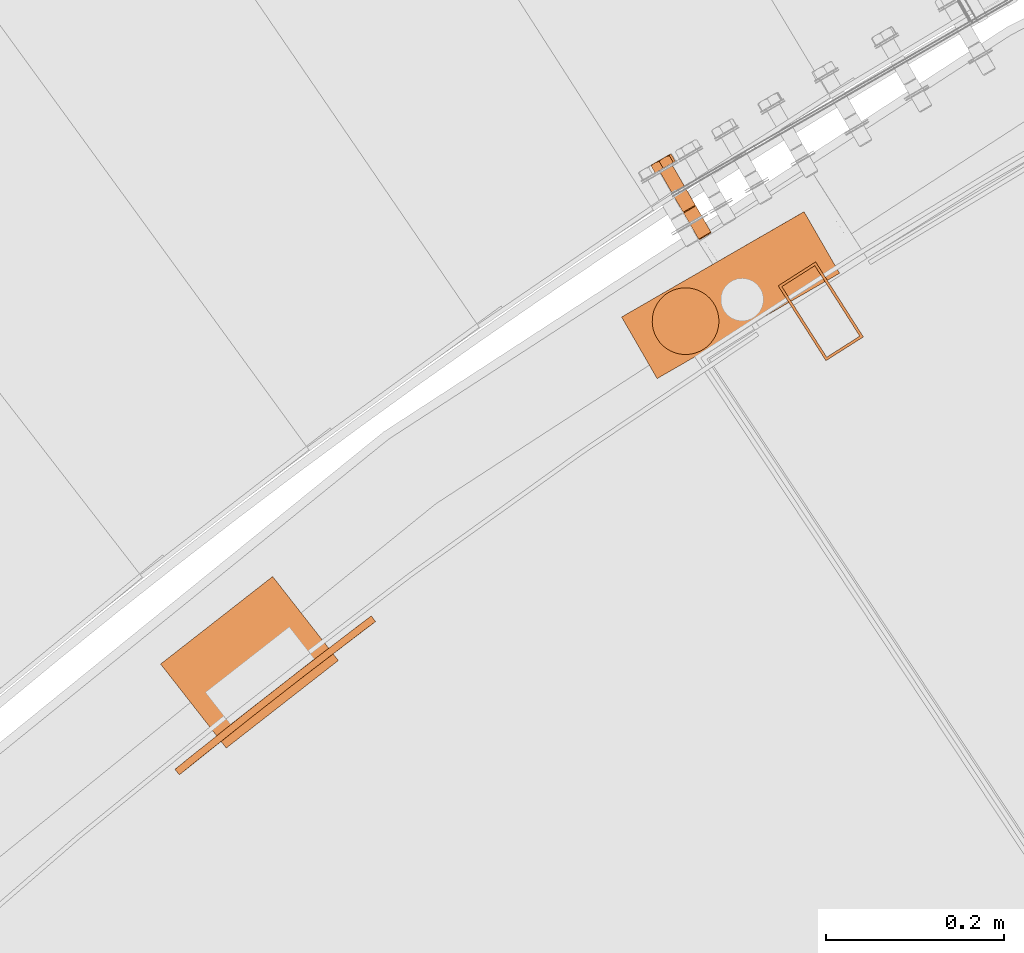
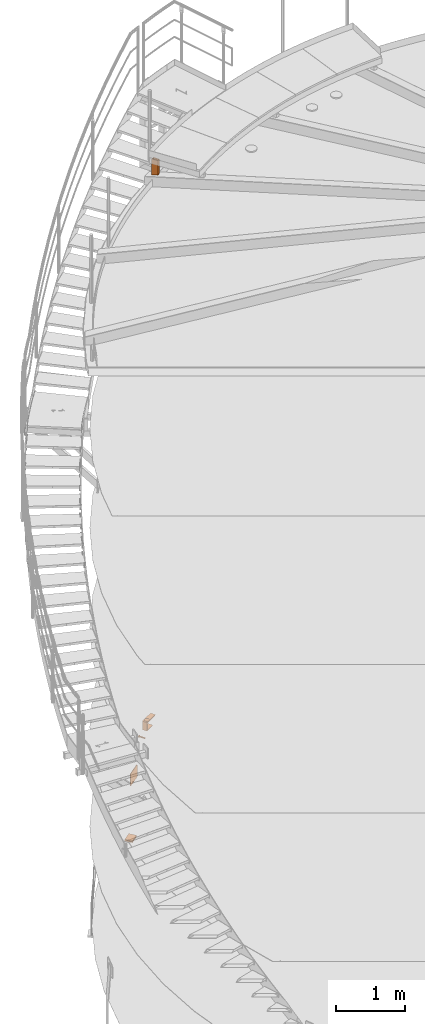
# One storey, part 77 of 126: 6 proxies.
"""IFC2X3 building model written with IfcOpenShell, lengths in millimetres."""

from ifc_helpers import new_model, si_unit, origin, origin_with_axes, place, context, project, spatial, faceted_brep, material, element, save


model = new_model("IFC2X3")

# Units and contexts
context_of_model_1 = context(None, 3, precision=0.1, world=origin())
context_of_model_2 = context(None, 3, precision=0.1, world=origin())
ifc_project = project(units=[si_unit("LENGTHUNIT", "METRE", prefix="MILLI"), si_unit("AREAUNIT", "SQUARE_METRE", prefix="CENTI"), si_unit("VOLUMEUNIT", "CUBIC_METRE", prefix="CENTI"), si_unit("MASSUNIT", "GRAM", prefix="KILO")], contexts=[context_of_model_1, context_of_model_2])

# Site, building, storey
site_placement = place(None, origin_with_axes())
site = spatial("IfcSite", under=ifc_project, at=site_placement, CompositionType="ELEMENT")
building_placement = place(site_placement, origin_with_axes())
building = spatial("IfcBuilding", under=site, at=building_placement, CompositionType="ELEMENT")
storey_placement = place(building_placement, origin_with_axes())
storey = spatial("IfcBuildingStorey", under=building, at=storey_placement, CompositionType="ELEMENT")

# Proxies
ifc_material = material(Name="STAHL")
proxy_1_placement = place(storey_placement, origin_with_axes())
element("IfcBuildingElementProxy", 1, at=proxy_1_placement, inside=storey, material=ifc_material, Name="profile", context=context_of_model_2, shape_type="Brep", body=[
    faceted_brep([(3665.8, 14681.7, 771.5), (3666.0, 14681.8, 769.6), (3667.4, 14681.4, 769.8), (3667.3, 14681.3, 771.5), (3666.1, 14681.9, 773.4), (3667.5, 14681.4, 773.1), (3666.8, 14682.2, 775.2), (3668.1, 14681.8, 774.7), (3667.8, 14682.8, 776.7), (3669.0, 14682.3, 776.0), (3669.1, 14683.6, 778.0), (3670.1, 14682.9, 777.0), (3670.6, 14684.5, 778.8), (3671.4, 14683.7, 777.8), (3672.2, 14685.4, 779.2), (3672.8, 14684.5, 778.1), (3673.9, 14686.4, 779.1), (3674.3, 14685.3, 778.0), (3675.5, 14687.3, 778.5), (3675.7, 14686.1, 777.5), (3676.9, 14688.1, 777.5), (3676.9, 14686.9, 776.7), (3678.1, 14688.8, 776.2), (3678.0, 14687.5, 775.5), (3679.0, 14689.3, 774.6), (3678.7, 14687.9, 774.1), (3679.5, 14689.6, 772.7), (3679.2, 14688.2, 772.5), (3648.3, 14712.0, 771.5), (3648.5, 14712.1, 769.6), (3649.9, 14711.7, 769.8), (3649.8, 14711.6, 771.5), (3648.6, 14712.2, 773.4), (3650.0, 14711.8, 773.1), (3649.3, 14712.6, 775.2), (3650.6, 14712.1, 774.7), (3650.3, 14713.1, 776.7), (3651.5, 14712.6, 776.0), (3651.6, 14713.9, 778.0), (3652.6, 14713.2, 777.0), (3653.1, 14714.8, 778.8), (3653.9, 14714.0, 777.8), (3654.7, 14715.7, 779.2), (3655.3, 14714.8, 778.1), (3656.4, 14716.7, 779.1), (3656.8, 14715.6, 778.0), (3658.0, 14717.6, 778.5), (3658.2, 14716.4, 777.5), (3659.4, 14718.4, 777.5), (3659.4, 14717.2, 776.7), (3660.6, 14719.1, 776.2), (3660.5, 14717.8, 775.5), (3661.5, 14719.6, 774.6), (3661.2, 14718.2, 774.1), (3662.0, 14719.9, 772.7), (3661.7, 14718.5, 772.5), (3679.7, 14689.7, 770.8), (3662.7, 14719.1, 770.8), (3662.6, 14719.0, 772.7), (3679.4, 14689.5, 768.9), (3662.4, 14718.9, 768.9), (3678.7, 14689.2, 767.1), (3661.8, 14718.5, 767.1), (3677.7, 14688.6, 765.6), (3660.8, 14717.9, 765.6), (3676.4, 14687.8, 764.4), (3659.5, 14717.2, 764.4), (3674.9, 14686.9, 763.6), (3658.0, 14716.3, 763.6), (3673.3, 14686.0, 763.2), (3656.3, 14715.4, 763.2), (3671.6, 14685.0, 763.3), (3654.6, 14714.4, 763.3), (3670.0, 14684.1, 763.8), (3653.0, 14713.5, 763.8), (3668.6, 14683.3, 764.8), (3651.6, 14712.7, 764.8), (3667.4, 14682.6, 766.1), (3650.4, 14712.0, 766.1), (3666.5, 14682.1, 767.8), (3649.5, 14711.5, 767.8), (3649.0, 14711.2, 769.6), (3634.6, 14766.3, 774.6), (3633.7, 14765.8, 776.2), (3635.1, 14766.6, 772.7), (3621.4, 14758.7, 771.5), (3621.5, 14758.8, 769.6), (3621.6, 14758.9, 773.4), (3622.3, 14759.3, 775.2), (3623.3, 14759.8, 776.7), (3624.6, 14760.6, 778.0), (3626.1, 14761.5, 778.8), (3627.8, 14762.4, 779.2), (3629.4, 14763.4, 779.1), (3631.0, 14764.3, 778.5), (3632.5, 14765.1, 777.5), (3649.0, 14712.4, 767.8), (3622.0, 14759.1, 767.8), (3622.9, 14759.6, 766.1), (3649.9, 14712.9, 766.1), (3662.2, 14720.0, 770.8), (3635.2, 14766.7, 770.8), (3661.9, 14719.8, 768.9), (3634.9, 14766.5, 768.9), (3661.2, 14719.5, 767.1), (3634.3, 14766.2, 767.1), (3660.2, 14718.9, 765.6), (3633.3, 14765.6, 765.6), (3658.9, 14718.1, 764.4), (3632.0, 14764.8, 764.4), (3657.4, 14717.3, 763.6), (3630.5, 14764.0, 763.6), (3655.8, 14716.3, 763.2), (3628.8, 14763.0, 763.2), (3654.1, 14715.4, 763.3), (3627.1, 14762.0, 763.3), (3652.5, 14714.4, 763.8), (3625.5, 14761.1, 763.8), (3651.1, 14713.6, 764.8), (3624.1, 14760.3, 764.8), (3616.9, 14756.1, 775.6), (3619.3, 14757.5, 762.0), (3630.6, 14764.1, 757.6), (3639.7, 14769.3, 766.7), (3637.3, 14767.9, 780.3), (3626.0, 14761.4, 784.8), (3626.2, 14771.8, 757.6), (3627.2, 14773.0, 758.9), (3628.3, 14774.0, 760.2), (3629.2, 14774.7, 761.2), (3630.1, 14775.3, 762.2), (3631.4, 14776.0, 763.4), (3632.8, 14776.5, 764.7), (3633.9, 14776.8, 765.7), (3635.2, 14777.0, 766.7), (3631.4, 14776.0, 763.7), (3632.4, 14776.6, 765.4), (3633.1, 14777.1, 767.3), (3633.6, 14777.3, 769.4), (3633.7, 14777.4, 771.4), (3633.8, 14777.4, 772.0), (3634.1, 14777.4, 770.5), (3634.6, 14777.2, 768.7), (3633.5, 14777.3, 773.5), (3620.0, 14769.4, 759.8), (3621.7, 14770.5, 759.3), (3623.5, 14771.5, 759.2), (3625.3, 14772.5, 759.4), (3627.1, 14773.5, 760.0), (3628.7, 14774.5, 760.9), (3624.6, 14771.4, 758.1), (3623.2, 14770.9, 758.6), (3621.5, 14770.3, 759.2), (3614.8, 14765.2, 762.0), (3614.3, 14765.4, 763.6), (3613.9, 14765.6, 765.1), (3613.5, 14765.6, 767.0), (3613.1, 14765.5, 768.8), (3613.6, 14765.8, 766.8), (3614.4, 14766.2, 765.0), (3615.5, 14766.9, 763.3), (3616.8, 14767.6, 761.8), (3618.3, 14768.5, 760.7), (3618.7, 14768.7, 760.3), (3617.6, 14767.8, 760.8), (3616.2, 14766.6, 761.4), (3633.2, 14777.0, 775.4), (3633.0, 14776.6, 777.2), (3632.9, 14776.2, 778.8), (3632.9, 14775.6, 780.3), (3631.0, 14775.1, 781.0), (3629.2, 14774.5, 781.6), (3627.9, 14774.0, 782.1), (3626.6, 14773.3, 782.5), (3625.1, 14772.3, 783.1), (3623.7, 14771.2, 783.8), (3622.6, 14770.2, 784.3), (3621.5, 14769.1, 784.8), (3612.5, 14763.9, 775.6), (3613.3, 14764.8, 776.7), (3614.1, 14765.7, 777.7), (3615.3, 14766.6, 779.0), (3616.4, 14767.4, 780.2), (3615.2, 14766.7, 778.7), (3614.2, 14766.1, 776.9), (3613.5, 14765.7, 775.0), (3613.0, 14765.4, 773.0), (3612.9, 14765.4, 770.9), (3612.9, 14765.3, 770.3), (3612.7, 14765.0, 771.8), (3612.5, 14764.5, 773.7), (3617.5, 14767.9, 781.2), (3618.5, 14768.4, 782.2), (3619.9, 14768.8, 783.5), (3624.9, 14772.3, 783.0), (3623.1, 14771.2, 783.2), (3621.3, 14770.2, 782.9), (3619.5, 14769.2, 782.4), (3617.9, 14768.3, 781.4), (3628.3, 14774.3, 781.7), (3633.0, 14777.0, 775.5), (3632.2, 14776.5, 777.4), (3631.1, 14775.9, 779.1), (3629.8, 14775.1, 780.5), (3648.9, 14711.1, 771.5), (3649.1, 14711.2, 773.4), (3649.8, 14711.6, 775.2), (3650.8, 14712.2, 776.7), (3652.1, 14713.0, 778.0), (3653.6, 14713.8, 778.8), (3655.3, 14714.8, 779.2), (3656.9, 14715.7, 779.1), (3658.5, 14716.7, 778.5), (3660.0, 14717.5, 777.5), (3661.2, 14718.2, 776.2), (3662.1, 14718.7, 774.6), (3650.4, 14711.9, 768.2), (3651.1, 14712.4, 766.8), (3652.2, 14713.0, 765.7), (3653.4, 14713.7, 764.8), (3654.8, 14714.5, 764.4), (3656.2, 14715.3, 764.3), (3657.7, 14716.2, 764.6), (3659.0, 14716.9, 765.3), (3660.1, 14717.6, 766.4), (3661.0, 14718.1, 767.7), (3661.5, 14718.4, 769.2), (3661.8, 14718.5, 770.9), (3667.9, 14681.6, 768.2), (3668.6, 14682.1, 766.8), (3669.7, 14682.7, 765.7), (3670.9, 14683.4, 764.8), (3672.3, 14684.2, 764.4), (3673.7, 14685.0, 764.3), (3675.2, 14685.8, 764.6), (3676.5, 14686.6, 765.3), (3677.6, 14687.2, 766.4), (3678.5, 14687.8, 767.7), (3679.0, 14688.1, 769.2), (3679.3, 14688.2, 770.9)], [[[0, 1, 2, 3]], [[4, 0, 3, 5]], [[6, 4, 5, 7]], [[8, 6, 7, 9]], [[10, 8, 9, 11]], [[12, 10, 11, 13]], [[14, 12, 13, 15]], [[16, 14, 15, 17]], [[18, 16, 17, 19]], [[20, 18, 19, 21]], [[22, 20, 21, 23]], [[24, 22, 23, 25]], [[26, 24, 25, 27]], [[28, 29, 30, 31]], [[32, 28, 31, 33]], [[34, 32, 33, 35]], [[36, 34, 35, 37]], [[38, 36, 37, 39]], [[40, 38, 39, 41]], [[42, 40, 41, 43]], [[44, 42, 43, 45]], [[46, 44, 45, 47]], [[48, 46, 47, 49]], [[50, 48, 49, 51]], [[52, 50, 51, 53]], [[54, 52, 53, 55]], [[26, 56, 57, 58]], [[56, 59, 60, 57]], [[59, 61, 62, 60]], [[61, 63, 64, 62]], [[63, 65, 66, 64]], [[65, 67, 68, 66]], [[67, 69, 70, 68]], [[69, 71, 72, 70]], [[71, 73, 74, 72]], [[73, 75, 76, 74]], [[75, 77, 78, 76]], [[77, 79, 80, 78]], [[1, 81, 80, 79]], [[52, 82, 83, 50]], [[54, 84, 82, 52]], [[29, 28, 85, 86]], [[32, 87, 85, 28]], [[34, 88, 87, 32]], [[36, 89, 88, 34]], [[38, 90, 89, 36]], [[40, 91, 90, 38]], [[42, 92, 91, 40]], [[44, 93, 92, 42]], [[46, 94, 93, 44]], [[48, 95, 94, 46]], [[50, 83, 95, 48]], [[96, 97, 98, 99]], [[29, 86, 97, 96]], [[54, 100, 101, 84]], [[102, 103, 101, 100]], [[104, 105, 103, 102]], [[106, 107, 105, 104]], [[108, 109, 107, 106]], [[110, 111, 109, 108]], [[112, 113, 111, 110]], [[114, 115, 113, 112]], [[116, 117, 115, 114]], [[118, 119, 117, 116]], [[99, 98, 119, 118]], [[120, 121, 122, 123, 124, 125, 120, 89, 90, 91, 92, 93, 94, 95, 83, 82, 84, 101, 103, 105, 107, 109, 111, 113, 115, 117, 119, 98, 97, 86, 85, 87, 88, 89]], [[122, 126, 127, 128, 129, 130, 131, 132, 133, 134, 123]], [[130, 135, 136, 137, 138, 139, 140, 141, 142, 134, 133, 132, 131]], [[143, 140, 139]], [[144, 145, 146, 147, 148, 149, 129, 128, 127, 126, 150, 151, 152]], [[130, 129, 149]], [[153, 154, 155, 156, 157, 158, 159, 160, 161, 162, 163, 164, 165]], [[144, 163, 162]], [[124, 123, 134, 142, 141, 140, 143, 166, 167, 168, 169]], [[125, 124, 169, 170, 171, 172, 173, 174, 175, 176, 177]], [[178, 179, 180, 181, 182, 183, 184, 185, 186, 187, 188, 189, 190]], [[157, 188, 187]], [[191, 192, 193, 177, 176, 175, 174, 173, 194, 195, 196, 197, 198]], [[182, 191, 198]], [[199, 171, 170, 169, 168, 167, 166, 143, 200, 201, 202, 203]], [[172, 171, 199]], [[173, 172, 199]], [[120, 125, 177, 193, 192, 191, 182, 181, 180, 179, 178]], [[120, 178, 190, 189, 188, 157, 156, 155, 154, 153, 121]], [[121, 153, 165, 164, 163, 144, 152, 151, 150, 126, 122]], [[187, 186, 185, 184, 183, 182, 198, 197, 196, 195, 194, 173, 199, 203, 202, 201, 200, 143, 139, 138, 137, 136, 135, 130, 149, 148, 147, 146, 145, 144, 162, 161, 160, 159, 158, 157]], [[204, 205, 206, 207, 208, 209, 210, 211, 212, 213, 214, 215, 58, 57, 60, 62, 64, 66, 68, 70, 72, 74, 76, 78, 80, 81, 204, 31, 30, 216, 217, 218, 219, 220, 221, 222, 223, 224, 225, 226, 227, 55, 53, 51, 49, 47, 45, 43, 41, 39, 37, 35, 33, 31]], [[100, 54, 55, 227]], [[102, 100, 227, 226]], [[104, 102, 226, 225]], [[106, 104, 225, 224]], [[108, 106, 224, 223]], [[110, 108, 223, 222]], [[112, 110, 222, 221]], [[114, 112, 221, 220]], [[116, 114, 220, 219]], [[118, 116, 219, 218]], [[99, 118, 218, 217]], [[96, 99, 217, 216]], [[29, 96, 216, 30]], [[26, 58, 215, 24]], [[1, 0, 204, 81]], [[4, 205, 204, 0]], [[6, 206, 205, 4]], [[8, 207, 206, 6]], [[10, 208, 207, 8]], [[12, 209, 208, 10]], [[14, 210, 209, 12]], [[16, 211, 210, 14]], [[18, 212, 211, 16]], [[20, 213, 212, 18]], [[22, 214, 213, 20]], [[24, 215, 214, 22]], [[3, 2, 228, 229, 230, 231, 232, 233, 234, 235, 236, 237, 238, 239, 27, 25, 23, 21, 19, 17, 15, 13, 11, 9, 7, 5]], [[56, 26, 27, 239]], [[59, 56, 239, 238]], [[61, 59, 238, 237]], [[63, 61, 237, 236]], [[65, 63, 236, 235]], [[67, 65, 235, 234]], [[69, 67, 234, 233]], [[71, 69, 233, 232]], [[73, 71, 232, 231]], [[75, 73, 231, 230]], [[77, 75, 230, 229]], [[79, 77, 229, 228]], [[1, 79, 228, 2]]]),
])
proxy_2_placement = place(storey_placement, origin_with_axes())
element("IfcBuildingElementProxy", 2, at=proxy_2_placement, inside=storey, material=ifc_material, Name="profile", context=context_of_model_2, shape_type="Brep", body=[
    faceted_brep([(3632.8, 14572.4, 1159.0), (3632.8, 14572.4, 1144.0), (3629.4, 14576.9, 1144.0), (3629.4, 14576.9, 1159.0), (3637.0, 14568.8, 1159.0), (3637.0, 14568.8, 1144.0), (3641.9, 14566.2, 1159.0), (3641.9, 14566.2, 1144.0), (3647.4, 14564.7, 1159.0), (3647.4, 14564.7, 1144.0), (3652.9, 14564.5, 1159.0), (3652.9, 14564.5, 1144.0), (3658.5, 14565.5, 1159.0), (3658.5, 14565.5, 1144.0), (3663.6, 14567.8, 1159.0), (3663.6, 14567.8, 1144.0), (3668.1, 14571.1, 1159.0), (3668.1, 14571.1, 1144.0), (3671.7, 14575.3, 1159.0), (3671.7, 14575.3, 1144.0), (3674.4, 14580.3, 1159.0), (3674.4, 14580.3, 1144.0), (3675.8, 14585.7, 1159.0), (3675.8, 14585.7, 1144.0), (3676.0, 14591.3, 1159.0), (3676.0, 14591.3, 1144.0), (3675.0, 14596.8, 1159.0), (3675.0, 14596.8, 1144.0), (3672.7, 14601.9, 1159.0), (3672.7, 14601.9, 1144.0), (3632.8, 14572.4, 1024.0), (3632.8, 14572.4, 1009.0), (3629.4, 14576.9, 1009.0), (3629.4, 14576.9, 1024.0), (3637.0, 14568.8, 1024.0), (3637.0, 14568.8, 1009.0), (3641.9, 14566.2, 1024.0), (3641.9, 14566.2, 1009.0), (3647.4, 14564.7, 1024.0), (3647.4, 14564.7, 1009.0), (3652.9, 14564.5, 1024.0), (3652.9, 14564.5, 1009.0), (3658.5, 14565.5, 1024.0), (3658.5, 14565.5, 1009.0), (3663.6, 14567.8, 1024.0), (3663.6, 14567.8, 1009.0), (3668.1, 14571.1, 1024.0), (3668.1, 14571.1, 1009.0), (3671.7, 14575.3, 1024.0), (3671.7, 14575.3, 1009.0), (3674.4, 14580.3, 1024.0), (3674.4, 14580.3, 1009.0), (3675.8, 14585.7, 1024.0), (3675.8, 14585.7, 1009.0), (3676.0, 14591.3, 1024.0), (3676.0, 14591.3, 1009.0), (3675.0, 14596.8, 1024.0), (3675.0, 14596.8, 1009.0), (3672.7, 14601.9, 1024.0), (3672.7, 14601.9, 1009.0), (3753.1, 14602.1, 1009.0), (3713.1, 14671.4, 1009.0), (3714.4, 14672.2, 1014.0), (3715.8, 14673.0, 1019.0), (3717.2, 14673.8, 1024.0), (3757.2, 14604.5, 1024.0), (3755.8, 14603.7, 1019.0), (3754.4, 14602.9, 1014.0), (3813.6, 14637.1, 1144.0), (3773.6, 14706.3, 1144.0), (3777.1, 14708.4, 1149.1), (3780.7, 14710.5, 1154.1), (3784.4, 14712.6, 1159.0), (3824.4, 14643.3, 1159.0), (3820.7, 14641.2, 1154.1), (3817.1, 14639.1, 1149.1), (3579.1, 14594.1, 1009.0), (3579.1, 14594.1, 1159.0), (3592.1, 14601.6, 1144.0), (3592.1, 14601.6, 1024.0), (3619.1, 14524.8, 1009.0), (3619.1, 14524.8, 1159.0), (3632.1, 14532.3, 1144.0), (3632.1, 14532.3, 1024.0), (3669.4, 14606.4, 1024.0), (3669.4, 14606.4, 1009.0), (3665.2, 14610.1, 1024.0), (3665.2, 14610.1, 1009.0), (3660.2, 14612.7, 1024.0), (3660.2, 14612.7, 1009.0), (3654.8, 14614.2, 1024.0), (3654.8, 14614.2, 1009.0), (3649.2, 14614.4, 1024.0), (3649.2, 14614.4, 1009.0), (3643.7, 14613.3, 1024.0), (3643.7, 14613.3, 1009.0), (3638.6, 14611.1, 1024.0), (3638.6, 14611.1, 1009.0), (3634.1, 14607.8, 1024.0), (3634.1, 14607.8, 1009.0), (3630.4, 14603.5, 1024.0), (3630.4, 14603.5, 1009.0), (3627.8, 14598.6, 1024.0), (3627.8, 14598.6, 1009.0), (3626.4, 14593.2, 1024.0), (3626.4, 14593.2, 1009.0), (3626.2, 14587.6, 1024.0), (3626.2, 14587.6, 1009.0), (3627.2, 14582.1, 1024.0), (3627.2, 14582.1, 1009.0), (3669.4, 14606.4, 1159.0), (3669.4, 14606.4, 1144.0), (3665.2, 14610.1, 1159.0), (3665.2, 14610.1, 1144.0), (3660.2, 14612.7, 1159.0), (3660.2, 14612.7, 1144.0), (3654.8, 14614.2, 1159.0), (3654.8, 14614.2, 1144.0), (3649.2, 14614.4, 1159.0), (3649.2, 14614.4, 1144.0), (3643.7, 14613.3, 1159.0), (3643.7, 14613.3, 1144.0), (3638.6, 14611.1, 1159.0), (3638.6, 14611.1, 1144.0), (3634.1, 14607.8, 1159.0), (3634.1, 14607.8, 1144.0), (3630.4, 14603.5, 1159.0), (3630.4, 14603.5, 1144.0), (3627.8, 14598.6, 1159.0), (3627.8, 14598.6, 1144.0), (3626.4, 14593.2, 1159.0), (3626.4, 14593.2, 1144.0), (3626.2, 14587.6, 1159.0), (3626.2, 14587.6, 1144.0), (3627.2, 14582.1, 1159.0), (3627.2, 14582.1, 1144.0)], [[[0, 1, 2, 3]], [[4, 5, 1, 0]], [[6, 7, 5, 4]], [[8, 9, 7, 6]], [[10, 11, 9, 8]], [[12, 13, 11, 10]], [[14, 15, 13, 12]], [[16, 17, 15, 14]], [[18, 19, 17, 16]], [[20, 21, 19, 18]], [[22, 23, 21, 20]], [[24, 25, 23, 22]], [[26, 27, 25, 24]], [[26, 28, 29, 27]], [[30, 31, 32, 33]], [[34, 35, 31, 30]], [[36, 37, 35, 34]], [[38, 39, 37, 36]], [[40, 41, 39, 38]], [[42, 43, 41, 40]], [[44, 45, 43, 42]], [[46, 47, 45, 44]], [[48, 49, 47, 46]], [[50, 51, 49, 48]], [[52, 53, 51, 50]], [[54, 55, 53, 52]], [[56, 57, 55, 54]], [[56, 58, 59, 57]], [[60, 61, 62, 63, 64, 65, 66, 67]], [[68, 69, 70, 71, 72, 73, 74, 75]], [[76, 77, 72, 71, 70, 69, 78, 79, 64, 63, 62, 61]], [[77, 76, 80, 81]], [[78, 82, 83, 79]], [[84, 85, 59, 58]], [[86, 87, 85, 84]], [[88, 89, 87, 86]], [[90, 91, 89, 88]], [[92, 93, 91, 90]], [[94, 95, 93, 92]], [[96, 97, 95, 94]], [[98, 99, 97, 96]], [[100, 101, 99, 98]], [[102, 103, 101, 100]], [[104, 105, 103, 102]], [[106, 107, 105, 104]], [[108, 109, 107, 106]], [[33, 32, 109, 108]], [[110, 111, 29, 28]], [[112, 113, 111, 110]], [[114, 115, 113, 112]], [[116, 117, 115, 114]], [[118, 119, 117, 116]], [[120, 121, 119, 118]], [[122, 123, 121, 120]], [[124, 125, 123, 122]], [[126, 127, 125, 124]], [[128, 129, 127, 126]], [[130, 131, 129, 128]], [[132, 133, 131, 130]], [[134, 135, 133, 132]], [[3, 2, 135, 134]], [[81, 73, 22, 20, 18, 16, 14, 12, 10, 8, 6, 4, 0, 3, 134, 132, 130, 128, 126, 124, 122, 120, 118, 116, 114, 112, 110, 28, 26, 24, 22, 73, 72, 77]], [[83, 65, 52, 50, 48, 46, 44, 42, 40, 38, 36, 34, 30, 33, 108, 106, 104, 102, 100, 98, 96, 94, 92, 90, 88, 86, 84, 58, 56, 54, 52, 65, 64, 79]], [[81, 80, 60, 67, 66, 65, 83, 82, 68, 75, 74, 73]], [[82, 78, 69, 115, 117, 119, 121, 123, 125, 127, 129, 131, 133, 135, 2, 1, 5, 7, 9, 11, 13, 15, 17, 19, 21, 23, 25, 27, 29, 111, 113, 115, 69, 68]], [[80, 76, 61, 89, 91, 93, 95, 97, 99, 101, 103, 105, 107, 109, 32, 31, 35, 37, 39, 41, 43, 45, 47, 49, 51, 53, 55, 57, 59, 85, 87, 89, 61, 60]]]),
])
proxy_3_placement = place(storey_placement, origin_with_axes())
element("IfcBuildingElementProxy", 3, at=proxy_3_placement, inside=storey, material=ifc_material, Name="profile", context=context_of_model_2, shape_type="Brep", body=[
    faceted_brep([(3625.6, 14594.5, 1161.0), (3625.6, 14594.5, 1159.0), (3626.4, 14597.6, 1159.0), (3626.4, 14597.6, 1161.0), (3625.1, 14591.2, 1161.0), (3625.1, 14591.2, 1159.0), (3625.1, 14588.0, 1161.0), (3625.1, 14588.0, 1159.0), (3671.2, 14605.9, 1161.0), (3671.2, 14605.9, 1159.0), (3673.1, 14603.2, 1159.0), (3673.1, 14603.2, 1161.0), (3625.5, 14584.7, 1161.0), (3625.5, 14584.7, 1159.0), (3669.0, 14608.3, 1161.0), (3669.0, 14608.3, 1159.0), (3626.3, 14581.6, 1161.0), (3626.3, 14581.6, 1159.0), (3666.5, 14610.4, 1161.0), (3666.5, 14610.4, 1159.0), (3627.5, 14578.5, 1161.0), (3627.5, 14578.5, 1159.0), (3663.8, 14612.1, 1161.0), (3663.8, 14612.1, 1159.0), (3629.0, 14575.7, 1161.0), (3629.0, 14575.7, 1159.0), (3660.8, 14613.5, 1161.0), (3660.8, 14613.5, 1159.0), (3657.7, 14614.6, 1161.0), (3657.7, 14614.6, 1159.0), (3654.5, 14615.2, 1161.0), (3654.5, 14615.2, 1159.0), (3651.3, 14615.4, 1161.0), (3651.3, 14615.4, 1159.0), (3648.0, 14615.2, 1161.0), (3648.0, 14615.2, 1159.0), (3644.8, 14614.7, 1161.0), (3644.8, 14614.7, 1159.0), (3641.7, 14613.7, 1161.0), (3641.7, 14613.7, 1159.0), (3638.7, 14612.3, 1161.0), (3638.7, 14612.3, 1159.0), (3635.9, 14610.6, 1161.0), (3635.9, 14610.6, 1159.0), (3633.4, 14608.5, 1161.0), (3633.4, 14608.5, 1159.0), (3631.2, 14606.1, 1161.0), (3631.2, 14606.1, 1159.0), (3629.2, 14603.5, 1161.0), (3629.2, 14603.5, 1159.0), (3627.6, 14600.7, 1161.0), (3627.6, 14600.7, 1159.0), (3685.9, 14575.4, 1160.5), (3684.2, 14571.8, 1160.5), (3684.2, 14571.8, 1159.0), (3685.9, 14575.4, 1159.0), (3619.3, 14569.6, 1160.5), (3619.3, 14569.6, 1159.0), (3621.5, 14566.3, 1159.0), (3621.5, 14566.3, 1160.5), (3687.1, 14579.1, 1160.5), (3687.1, 14579.1, 1159.0), (3624.1, 14563.4, 1159.0), (3624.1, 14563.4, 1160.5), (3688.0, 14582.9, 1160.5), (3688.0, 14582.9, 1159.0), (3627.0, 14560.7, 1159.0), (3627.0, 14560.7, 1160.5), (3688.5, 14586.8, 1160.5), (3688.5, 14586.8, 1159.0), (3630.1, 14558.3, 1159.0), (3630.1, 14558.3, 1160.5), (3688.6, 14590.7, 1160.5), (3688.6, 14590.7, 1159.0), (3633.5, 14556.3, 1159.0), (3633.5, 14556.3, 1160.5), (3637.0, 14554.7, 1159.0), (3637.0, 14554.7, 1160.5), (3688.2, 14594.7, 1160.5), (3688.2, 14594.7, 1159.0), (3640.7, 14553.4, 1159.0), (3640.7, 14553.4, 1160.5), (3687.5, 14598.5, 1160.5), (3687.5, 14598.5, 1159.0), (3644.6, 14552.5, 1159.0), (3644.6, 14552.5, 1160.5), (3686.3, 14602.3, 1160.5), (3686.3, 14602.3, 1159.0), (3648.5, 14552.0, 1159.0), (3648.5, 14552.0, 1160.5), (3684.8, 14605.9, 1160.5), (3684.8, 14605.9, 1159.0), (3682.9, 14609.3, 1159.0), (3682.9, 14609.3, 1160.5), (3652.4, 14552.0, 1159.0), (3652.4, 14552.0, 1160.5), (3656.3, 14552.3, 1159.0), (3656.3, 14552.3, 1160.5), (3660.2, 14553.0, 1160.5), (3660.2, 14553.0, 1159.0), (3663.9, 14554.2, 1160.5), (3663.9, 14554.2, 1159.0), (3667.5, 14555.7, 1160.5), (3667.5, 14555.7, 1159.0), (3671.0, 14557.6, 1160.5), (3671.0, 14557.6, 1159.0), (3674.2, 14559.9, 1160.5), (3674.2, 14559.9, 1159.0), (3677.1, 14562.5, 1160.5), (3677.1, 14562.5, 1159.0), (3679.8, 14565.3, 1160.5), (3679.8, 14565.3, 1159.0), (3682.2, 14568.5, 1160.5), (3682.2, 14568.5, 1159.0), (3680.6, 14612.5, 1160.5), (3678.1, 14615.5, 1160.5), (3675.2, 14618.2, 1160.5), (3672.1, 14620.5, 1160.5), (3668.7, 14622.5, 1160.5), (3665.1, 14624.2, 1160.5), (3661.4, 14625.5, 1160.5), (3657.6, 14626.4, 1160.5), (3653.7, 14626.8, 1160.5), (3653.7, 14626.3, 1161.0), (3657.5, 14625.9, 1161.0), (3661.3, 14625.0, 1161.0), (3664.9, 14623.7, 1161.0), (3668.5, 14622.1, 1161.0), (3671.8, 14620.1, 1161.0), (3674.9, 14617.8, 1161.0), (3677.7, 14615.1, 1161.0), (3680.2, 14612.2, 1161.0), (3682.5, 14609.0, 1161.0), (3684.3, 14605.7, 1161.0), (3685.8, 14602.1, 1161.0), (3687.0, 14598.4, 1161.0), (3687.7, 14594.6, 1161.0), (3688.1, 14590.7, 1161.0), (3688.0, 14586.9, 1161.0), (3687.5, 14583.0, 1161.0), (3686.6, 14579.2, 1161.0), (3685.4, 14575.6, 1161.0), (3683.8, 14572.1, 1161.0), (3681.8, 14568.7, 1161.0), (3679.4, 14565.6, 1161.0), (3676.8, 14562.8, 1161.0), (3673.9, 14560.3, 1161.0), (3670.7, 14558.1, 1161.0), (3667.3, 14556.2, 1161.0), (3663.7, 14554.7, 1161.0), (3660.0, 14553.5, 1161.0), (3656.2, 14552.8, 1161.0), (3652.4, 14552.5, 1161.0), (3648.5, 14552.5, 1161.0), (3644.7, 14553.0, 1161.0), (3640.9, 14553.9, 1161.0), (3637.2, 14555.1, 1161.0), (3633.7, 14556.8, 1161.0), (3630.4, 14558.8, 1161.0), (3627.3, 14561.1, 1161.0), (3624.5, 14563.7, 1161.0), (3621.9, 14566.7, 1161.0), (3619.7, 14569.8, 1161.0), (3617.8, 14573.2, 1161.0), (3616.3, 14576.8, 1161.0), (3615.2, 14580.5, 1161.0), (3614.4, 14584.3, 1161.0), (3614.1, 14588.1, 1161.0), (3614.2, 14592.0, 1161.0), (3614.6, 14595.9, 1161.0), (3615.5, 14599.6, 1161.0), (3616.8, 14603.3, 1161.0), (3618.4, 14606.8, 1161.0), (3620.4, 14610.1, 1161.0), (3622.7, 14613.2, 1161.0), (3625.4, 14616.0, 1161.0), (3628.3, 14618.6, 1161.0), (3631.5, 14620.8, 1161.0), (3634.9, 14622.7, 1161.0), (3638.4, 14624.2, 1161.0), (3642.1, 14625.3, 1161.0), (3645.9, 14626.1, 1161.0), (3649.8, 14626.4, 1161.0), (3649.8, 14626.9, 1160.5), (3645.9, 14626.6, 1160.5), (3642.0, 14625.8, 1160.5), (3638.3, 14624.7, 1160.5), (3634.6, 14623.1, 1160.5), (3631.2, 14621.2, 1160.5), (3628.0, 14619.0, 1160.5), (3625.0, 14616.4, 1160.5), (3622.4, 14613.5, 1160.5), (3620.0, 14610.4, 1160.5), (3618.0, 14607.0, 1160.5), (3616.3, 14603.5, 1160.5), (3615.0, 14599.8, 1160.5), (3614.2, 14595.9, 1160.5), (3613.7, 14592.0, 1160.5), (3613.6, 14588.1, 1160.5), (3613.9, 14584.2, 1160.5), (3614.7, 14580.4, 1160.5), (3615.8, 14576.6, 1160.5), (3617.4, 14573.0, 1160.5), (3620.0, 14610.4, 1159.0), (3618.0, 14607.0, 1159.0), (3616.3, 14603.5, 1159.0), (3615.0, 14599.8, 1159.0), (3680.6, 14612.5, 1159.0), (3614.2, 14595.9, 1159.0), (3613.7, 14592.0, 1159.0), (3678.1, 14615.5, 1159.0), (3613.6, 14588.1, 1159.0), (3675.2, 14618.2, 1159.0), (3613.9, 14584.2, 1159.0), (3672.1, 14620.5, 1159.0), (3614.7, 14580.4, 1159.0), (3668.7, 14622.5, 1159.0), (3615.8, 14576.6, 1159.0), (3665.1, 14624.2, 1159.0), (3617.4, 14573.0, 1159.0), (3661.4, 14625.5, 1159.0), (3657.6, 14626.4, 1159.0), (3653.7, 14626.8, 1159.0), (3649.8, 14626.9, 1159.0), (3645.9, 14626.6, 1159.0), (3642.0, 14625.8, 1159.0), (3638.3, 14624.7, 1159.0), (3634.6, 14623.1, 1159.0), (3631.2, 14621.2, 1159.0), (3628.0, 14619.0, 1159.0), (3625.0, 14616.4, 1159.0), (3622.4, 14613.5, 1159.0), (3674.7, 14600.3, 1161.0), (3675.9, 14597.3, 1161.0), (3676.7, 14594.1, 1161.0), (3677.0, 14590.9, 1161.0), (3677.0, 14587.6, 1161.0), (3676.6, 14584.4, 1161.0), (3675.8, 14581.2, 1161.0), (3674.5, 14578.2, 1161.0), (3672.9, 14575.3, 1161.0), (3671.0, 14572.7, 1161.0), (3668.7, 14570.4, 1161.0), (3666.2, 14568.3, 1161.0), (3663.4, 14566.6, 1161.0), (3660.5, 14565.2, 1161.0), (3657.4, 14564.2, 1161.0), (3654.2, 14563.6, 1161.0), (3650.9, 14563.4, 1161.0), (3647.6, 14563.7, 1161.0), (3644.4, 14564.3, 1161.0), (3641.3, 14565.3, 1161.0), (3638.4, 14566.7, 1161.0), (3635.7, 14568.5, 1161.0), (3633.2, 14570.6, 1161.0), (3630.9, 14573.0, 1161.0), (3676.6, 14584.4, 1159.0), (3675.8, 14581.2, 1159.0), (3677.0, 14587.6, 1159.0), (3677.0, 14590.9, 1159.0), (3630.9, 14573.0, 1159.0), (3676.7, 14594.1, 1159.0), (3633.2, 14570.6, 1159.0), (3675.9, 14597.3, 1159.0), (3635.7, 14568.5, 1159.0), (3674.7, 14600.3, 1159.0), (3638.4, 14566.7, 1159.0), (3641.3, 14565.3, 1159.0), (3644.4, 14564.3, 1159.0), (3647.6, 14563.7, 1159.0), (3650.9, 14563.4, 1159.0), (3654.2, 14563.6, 1159.0), (3657.4, 14564.2, 1159.0), (3660.5, 14565.2, 1159.0), (3663.4, 14566.6, 1159.0), (3666.2, 14568.3, 1159.0), (3668.7, 14570.4, 1159.0), (3671.0, 14572.7, 1159.0), (3672.9, 14575.3, 1159.0), (3674.5, 14578.2, 1159.0)], [[[0, 1, 2, 3]], [[4, 5, 1, 0]], [[6, 7, 5, 4]], [[8, 9, 10, 11]], [[12, 13, 7, 6]], [[14, 15, 9, 8]], [[16, 17, 13, 12]], [[18, 19, 15, 14]], [[20, 21, 17, 16]], [[22, 23, 19, 18]], [[24, 25, 21, 20]], [[26, 27, 23, 22]], [[28, 29, 27, 26]], [[30, 31, 29, 28]], [[32, 33, 31, 30]], [[34, 35, 33, 32]], [[36, 37, 35, 34]], [[38, 39, 37, 36]], [[40, 41, 39, 38]], [[42, 43, 41, 40]], [[44, 45, 43, 42]], [[46, 47, 45, 44]], [[48, 49, 47, 46]], [[50, 51, 49, 48]], [[3, 2, 51, 50]], [[52, 53, 54, 55]], [[56, 57, 58, 59]], [[60, 52, 55, 61]], [[59, 58, 62, 63]], [[64, 60, 61, 65]], [[63, 62, 66, 67]], [[68, 64, 65, 69]], [[67, 66, 70, 71]], [[72, 68, 69, 73]], [[71, 70, 74, 75]], [[75, 74, 76, 77]], [[78, 72, 73, 79]], [[77, 76, 80, 81]], [[82, 78, 79, 83]], [[81, 80, 84, 85]], [[86, 82, 83, 87]], [[85, 84, 88, 89]], [[90, 86, 87, 91]], [[90, 91, 92, 93]], [[89, 88, 94, 95]], [[95, 94, 96, 97]], [[98, 97, 96, 99]], [[100, 98, 99, 101]], [[102, 100, 101, 103]], [[104, 102, 103, 105]], [[106, 104, 105, 107]], [[108, 106, 107, 109]], [[110, 108, 109, 111]], [[112, 110, 111, 113]], [[53, 112, 113, 54]], [[89, 95, 97, 98, 100, 102, 104, 106, 108, 110, 112, 53, 52, 60, 64, 68, 72, 78, 82, 86, 90, 93, 114, 115, 116, 117, 118, 119, 120, 121, 122, 123, 124, 125, 126, 127, 128, 129, 130, 131, 132, 133, 134, 135, 136, 137, 138, 139, 140, 141, 142, 143, 144, 145, 146, 147, 148, 149, 150, 151, 152, 153, 154, 155, 156, 157, 158, 159, 160, 161, 162, 163, 164, 165, 166, 167, 168, 169, 170, 171, 172, 173, 174, 175, 176, 177, 178, 179, 180, 181, 182, 123, 122, 183, 184, 185, 186, 187, 188, 189, 190, 191, 192, 193, 194, 195, 196, 197, 198, 199, 200, 201, 202, 56, 59, 63, 67, 71, 75, 77, 81, 85]], [[193, 192, 203, 204]], [[193, 204, 205, 194]], [[194, 205, 206, 195]], [[114, 93, 92, 207]], [[195, 206, 208, 196]], [[196, 208, 209, 197]], [[115, 114, 207, 210]], [[197, 209, 211, 198]], [[116, 115, 210, 212]], [[198, 211, 213, 199]], [[117, 116, 212, 214]], [[199, 213, 215, 200]], [[118, 117, 214, 216]], [[200, 215, 217, 201]], [[119, 118, 216, 218]], [[201, 217, 219, 202]], [[120, 119, 218, 220]], [[202, 219, 57, 56]], [[121, 120, 220, 221]], [[122, 121, 221, 222]], [[183, 122, 222, 223]], [[184, 183, 223, 224]], [[185, 184, 224, 225]], [[186, 185, 225, 226]], [[187, 186, 226, 227]], [[187, 227, 228, 188]], [[188, 228, 229, 189]], [[189, 229, 230, 190]], [[190, 230, 231, 191]], [[191, 231, 203, 192]], [[153, 152, 151, 150, 149, 148, 147, 146, 145, 144, 143, 142, 141, 140, 139, 138, 137, 136, 135, 134, 133, 132, 131, 130, 129, 128, 127, 126, 125, 124, 28, 26, 22, 18, 14, 8, 11, 232, 233, 234, 235, 236, 237, 238, 239, 240, 241, 242, 243, 244, 245, 246, 247, 248, 249, 250, 251, 252, 253, 254, 255, 24, 20, 16, 12, 6, 4, 0, 3, 50, 48, 46, 44, 42, 40, 38, 36, 34, 32, 30, 28, 124, 123, 182, 181, 180, 179, 178, 177, 176, 175, 174, 173, 172, 171, 170, 169, 168, 167, 166, 165, 164, 163, 162, 161, 160, 159, 158, 157, 156, 155, 154]], [[237, 256, 257, 238]], [[236, 258, 256, 237]], [[235, 259, 258, 236]], [[255, 260, 25, 24]], [[234, 261, 259, 235]], [[254, 262, 260, 255]], [[233, 263, 261, 234]], [[253, 264, 262, 254]], [[232, 265, 263, 233]], [[232, 11, 10, 265]], [[252, 266, 264, 253]], [[251, 267, 266, 252]], [[250, 268, 267, 251]], [[249, 269, 268, 250]], [[248, 270, 269, 249]], [[247, 271, 270, 248]], [[246, 272, 271, 247]], [[245, 273, 272, 246]], [[244, 274, 273, 245]], [[243, 275, 274, 244]], [[242, 276, 275, 243]], [[241, 277, 276, 242]], [[240, 278, 277, 241]], [[239, 279, 278, 240]], [[238, 257, 279, 239]], [[88, 84, 80, 76, 74, 70, 66, 62, 58, 57, 219, 217, 215, 213, 211, 209, 208, 206, 205, 204, 203, 231, 230, 229, 228, 227, 226, 225, 224, 223, 222, 221, 220, 29, 31, 33, 35, 37, 39, 41, 43, 45, 47, 49, 51, 2, 1, 5, 7, 13, 17, 21, 25, 260, 262, 264, 266, 267, 268, 269, 270, 271, 272, 273, 274, 275, 276, 277, 278, 279, 257, 256, 258, 259, 261, 263, 265, 10, 9, 15, 19, 23, 27, 29, 220, 218, 216, 214, 212, 210, 207, 92, 91, 87, 83, 79, 73, 69, 65, 61, 55, 54, 113, 111, 109, 107, 105, 103, 101, 99, 96, 94]]]),
])
proxy_4_placement = place(storey_placement, origin_with_axes())
element("IfcBuildingElementProxy", 4, at=proxy_4_placement, inside=storey, material=ifc_material, Name="profile", context=context_of_model_2, shape_type="Brep", body=[
    faceted_brep([(3292.0, 14243.7, 704.7), (3295.4, 14246.2, 701.2), (3290.6, 14252.6, 701.2), (3286.8, 14249.8, 705.1), (3288.0, 14240.7, 707.5), (3282.4, 14246.4, 707.9), (3283.3, 14237.1, 709.4), (3278.0, 14243.1, 709.5), (3100.8, 14094.5, 709.5), (3105.0, 14097.9, 710.0), (3162.4, 14143.6, 710.0), (3220.2, 14188.8, 710.0), (3278.5, 14233.4, 710.0), (3273.7, 14239.8, 710.0), (3215.3, 14195.1, 710.0), (3157.5, 14149.9, 710.0), (3100.0, 14104.1, 710.0), (3095.3, 14100.3, 709.4), (3085.8, 14082.4, 697.0), (3088.5, 14084.6, 701.2), (3083.5, 14090.8, 701.2), (3080.5, 14088.4, 696.5), (3083.6, 14080.7, 692.0), (3078.3, 14086.6, 690.9), (3082.2, 14079.5, 686.0), (3077.0, 14085.6, 685.5), (3081.7, 14079.1, 680.0), (3076.6, 14085.3, 680.0), (3076.6, 14085.3, 520.0), (3077.1, 14085.7, 514.0), (3082.1, 14079.4, 514.5), (3081.7, 14079.1, 520.0), (3287.2, 14250.1, 495.3), (3290.6, 14252.6, 498.8), (3295.4, 14246.2, 498.8), (3291.6, 14243.4, 494.9), (3283.2, 14247.1, 492.5), (3287.2, 14240.0, 492.1), (3278.5, 14243.5, 490.6), (3282.8, 14236.8, 490.5), (3100.3, 14094.1, 490.6), (3095.7, 14100.7, 490.5), (3100.0, 14104.1, 490.0), (3157.5, 14149.9, 490.0), (3215.3, 14195.1, 490.0), (3273.7, 14239.8, 490.0), (3278.5, 14233.4, 490.0), (3220.2, 14188.8, 490.0), (3162.4, 14143.6, 490.0), (3105.0, 14097.9, 490.0), (3080.7, 14088.6, 503.0), (3083.5, 14090.8, 498.8), (3088.5, 14084.6, 498.8), (3085.5, 14082.2, 503.5), (3078.6, 14086.9, 508.0), (3083.3, 14080.4, 509.1), (3091.5, 14097.3, 492.1), (3095.7, 14090.4, 492.5), (3087.1, 14093.8, 494.9), (3091.8, 14087.3, 495.3), (3301.9, 14251.2, 514.0), (3297.2, 14257.6, 514.5), (3297.6, 14257.9, 520.0), (3297.6, 14257.9, 680.0), (3297.1, 14257.5, 686.0), (3302.0, 14251.2, 685.5), (3302.4, 14251.5, 680.0), (3302.4, 14251.5, 520.0), (3295.9, 14256.7, 509.1), (3300.4, 14250.0, 508.0), (3293.6, 14254.9, 503.5), (3298.2, 14248.4, 503.0), (3096.5, 14091.1, 707.9), (3090.6, 14096.6, 707.5), (3092.2, 14087.6, 705.1), (3086.8, 14093.5, 704.7), (3300.8, 14250.3, 690.9), (3295.6, 14256.4, 692.0), (3298.5, 14248.5, 696.5), (3293.4, 14254.7, 697.0)], [[[0, 1, 2, 3]], [[4, 0, 3, 5]], [[6, 4, 5, 7]], [[8, 9, 10, 11, 12, 6, 7, 13, 14, 15, 16, 17]], [[18, 19, 20, 21]], [[22, 18, 21, 23]], [[24, 22, 23, 25]], [[26, 24, 25, 27, 28, 29, 30, 31]], [[32, 33, 34, 35]], [[36, 32, 35, 37]], [[38, 36, 37, 39]], [[40, 41, 42, 43, 44, 45, 38, 39, 46, 47, 48, 49]], [[50, 51, 52, 53]], [[54, 50, 53, 55]], [[29, 54, 55, 30]], [[56, 41, 40, 57]], [[58, 56, 57, 59]], [[51, 58, 59, 52]], [[60, 61, 62, 63, 64, 65, 66, 67]], [[68, 61, 60, 69]], [[70, 68, 69, 71]], [[33, 70, 71, 34]], [[72, 8, 17, 73]], [[74, 72, 73, 75]], [[19, 74, 75, 20]], [[76, 65, 64, 77]], [[78, 76, 77, 79]], [[1, 78, 79, 2]], [[26, 31, 30, 55, 53, 52, 59, 57, 40, 49, 48, 47, 46, 39, 37, 35, 34, 71, 69, 60, 67, 66, 65, 76, 78, 1, 0, 4, 6, 12, 11, 10, 9, 8, 72, 74, 19, 18, 22, 24]], [[28, 27, 25, 23, 21, 20, 75, 73, 17, 16, 15, 14, 13, 7, 5, 3, 2, 79, 77, 64, 63, 62, 61, 68, 70, 33, 32, 36, 38, 45, 44, 43, 42, 41, 56, 58, 51, 50, 54, 29]]]),
])
proxy_5_placement = place(storey_placement, origin_with_axes())
element("IfcBuildingElementProxy", 5, at=proxy_5_placement, inside=storey, material=ifc_material, Name="profile", context=context_of_model_2, shape_type="Brep", body=[
    faceted_brep([(3134.4, 14109.2, -530.0), (3060.5, 14203.7, -530.0), (3186.6, 14302.2, -530.0), (3260.5, 14207.7, -530.0), (3060.5, 14203.7, -500.0), (3186.6, 14302.2, -500.0), (3134.4, 14109.2, -500.0), (3260.5, 14207.7, -500.0)], [[[0, 1, 2, 3]], [[1, 4, 5, 2]], [[4, 6, 7, 5]], [[6, 0, 3, 7]], [[1, 0, 6, 4]], [[7, 3, 2, 5]]]),
])
proxy_6_placement = place(storey_placement, origin_with_axes())
element("IfcBuildingElementProxy", 6, at=proxy_6_placement, inside=storey, material=ifc_material, Name="profile", context=context_of_model_2, shape_type="Brep", body=[
    faceted_brep([(3755.3, 14629.2, 10673.4), (3809.0, 14544.9, 10700.2), (3809.0, 14544.9, 10955.2), (3755.3, 14629.2, 10955.2), (3851.2, 14571.7, 10700.2), (3851.2, 14571.7, 10955.2), (3797.4, 14656.1, 10673.4), (3797.4, 14656.1, 10955.2), (3809.9, 14549.0, 10699.4), (3759.4, 14628.3, 10674.2), (3759.4, 14628.3, 10955.2), (3809.9, 14549.0, 10955.2), (3796.5, 14651.9, 10674.2), (3796.5, 14651.9, 10955.2), (3847.0, 14572.6, 10699.4), (3847.0, 14572.6, 10955.2)], [[[0, 1, 2, 3]], [[1, 4, 5, 2]], [[4, 6, 7, 5]], [[6, 0, 3, 7]], [[8, 9, 10, 11]], [[9, 12, 13, 10]], [[12, 14, 15, 13]], [[14, 8, 11, 15]], [[1, 0, 6, 4], [9, 8, 14, 12]], [[2, 5, 7, 3], [15, 11, 10, 13]]]),
])

save(model, "model.ifc")
